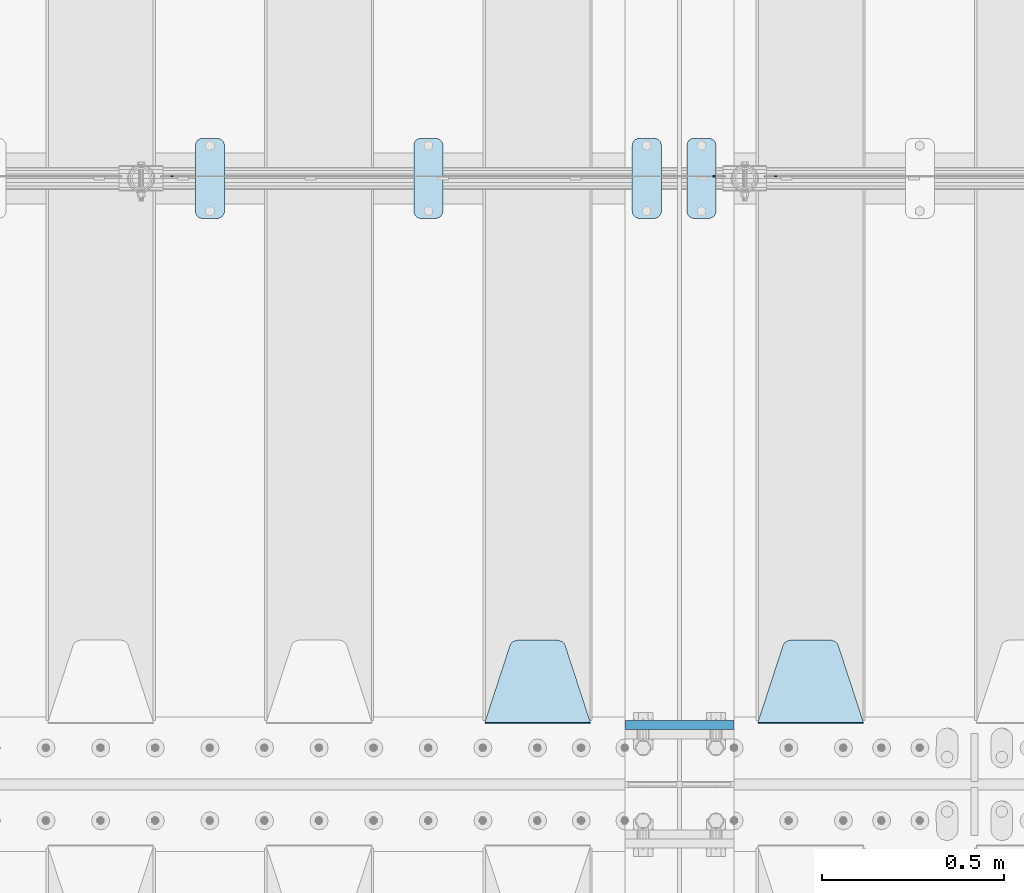
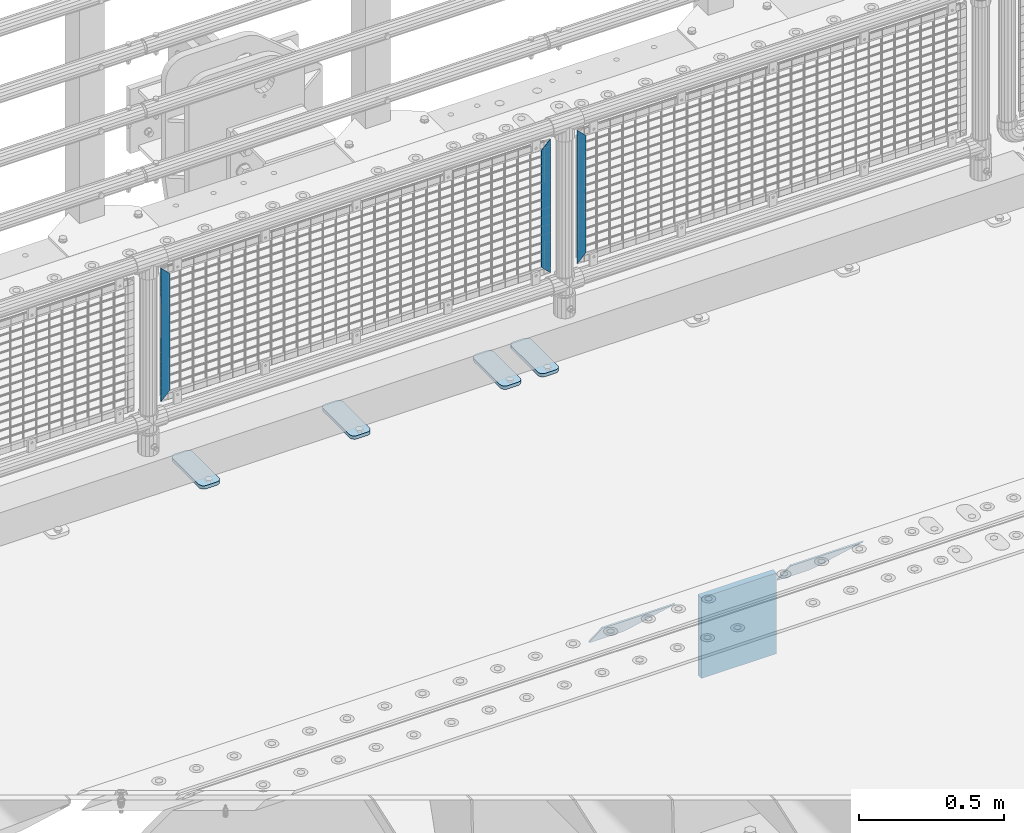
# One storey, part 173 of 193: 10 plates.
"""IFC2X3 building model written with IfcOpenShell, lengths in millimetres."""

from ifc_helpers import new_model, si_unit, frame, origin_with_axes, place, context, subcontext, project, spatial, faceted_brep, material, type_object, element, save


model = new_model("IFC2X3")

# Units and contexts
model_context = context("Model", 3, precision=1e-05, world=origin_with_axes())
body_context = subcontext(model_context, "Body", "Model", "MODEL_VIEW")
ifc_project = project(units=[si_unit("LENGTHUNIT", "METRE", prefix="MILLI"), si_unit("AREAUNIT", "SQUARE_METRE"), si_unit("VOLUMEUNIT", "CUBIC_METRE"), si_unit("MASSUNIT", "GRAM", prefix="KILO"), si_unit("TIMEUNIT", "SECOND"), si_unit("PLANEANGLEUNIT", "RADIAN"), si_unit("SOLIDANGLEUNIT", "STERADIAN"), si_unit("THERMODYNAMICTEMPERATUREUNIT", "DEGREE_CELSIUS"), si_unit("LUMINOUSINTENSITYUNIT", "LUMEN")], contexts=[model_context])

# Site, building, storey
site_placement = place(None, origin_with_axes())
site = spatial("IfcSite", under=ifc_project, at=site_placement, CompositionType="ELEMENT")
building_placement = place(site_placement, origin_with_axes())
building = spatial("IfcBuilding", under=site, at=building_placement, Name="Standard", CompositionType="ELEMENT")
storey_placement = place(building_placement, origin_with_axes())
storey = spatial("IfcBuildingStorey", under=building, at=storey_placement, Name="Undefined", CompositionType="ELEMENT", Elevation=0.0)

# Plates
ifc_material_1 = material(Name="STEEL/S355N")
plate_type_1 = type_object("IfcPlateType", PredefinedType="NOTDEFINED")
plate_1_placement = place(storey_placement, frame((-32210.0, 27162.5, -340.000000000044), z_axis=(0.0, 0.0, 1.0), x_axis=(1.0, 0.0, 0.0)))
element("IfcPlate", 1, at=plate_1_placement, inside=storey, type_object=plate_type_1, material=ifc_material_1, context=body_context, shape_type="Brep", body=[
    faceted_brep([(0.0, -12.5, 0.0), (9.27684595808387e-10, -12.5, 340.0), (9.27684595808387e-10, 12.5, 340.0), (0.0, 12.5, 0.0), (300.0, -12.5, 340.0), (300.0, 12.5, 340.0), (300.0, -12.5, 0.0), (300.0, 12.5, 0.0)], [[[0, 1, 2, 3]], [[1, 4, 5, 2]], [[4, 6, 7, 5]], [[6, 0, 3, 7]], [[5, 7, 3, 2]], [[6, 4, 1, 0]]]),
])
plate_type_2 = type_object("IfcPlateType", PredefinedType="NOTDEFINED")
plate_2_placement = place(storey_placement, frame((-31555.0, 27168.232233047, -1.76776695296758), z_axis=(0.0, 0.707106781186547, -0.707106781186548), x_axis=(-1.0, 0.0, 0.0)))
element("IfcPlate", 2, at=plate_2_placement, inside=storey, type_object=plate_type_2, material=ifc_material_1, context=body_context, shape_type="Brep", body=[
    faceted_brep([(0.0, -2.5, 0.0), (69.345504679477, -2.50000000000364, 300.171731424831), (69.345504679477, 2.49999999999636, 300.171731424831), (0.0, 2.5, 0.0), (70.9274061199576, -2.50000000000364, 304.897442415397), (70.9274061199576, 2.49999999999636, 304.897442415397), (73.3818627772307, -2.50000000000364, 309.234538108529), (73.3818627772307, 2.49999999999636, 309.234538108529), (76.6187032999551, -2.50000000000728, 313.023683126103), (76.6187032999551, 2.49999999999636, 313.023683126103), (80.5190132704993, -2.50000000000364, 316.125672595372), (80.5190132704993, 2.49999999999636, 316.125672595368), (84.9395038596849, -2.50000000000364, 318.426546230472), (84.9395038596849, 2.49999999999636, 318.426546230476), (89.7177759439219, -2.50000000000364, 319.841774983273), (89.7177759439219, 2.49999999999636, 319.841774983277), (94.678286292652, -2.50000000000364, 320.319366455074), (94.678286292652, 2.49999999999636, 320.319366455074), (195.321713707348, -2.50000000000364, 320.319366455074), (195.321713707348, 2.49999999999636, 320.319366455074), (200.282224056078, -2.50000000000364, 319.841774983273), (200.282224056078, 2.49999999999636, 319.841774983277), (205.060496140315, -2.50000000000364, 318.426546230472), (205.060496140315, 2.49999999999636, 318.426546230472), (209.480986729501, -2.50000000000364, 316.125672595372), (209.480986729501, 2.49999999999636, 316.125672595368), (213.381296700045, -2.50000000000728, 313.023683126103), (213.381296700045, 2.49999999999272, 313.023683126103), (216.618137222769, -2.50000000000364, 309.234538108525), (216.618137222769, 2.49999999999636, 309.234538108522), (219.072593880042, -2.50000000000364, 304.897442415397), (219.072593880042, 2.49999999999636, 304.897442415397), (220.654495320523, -2.50000000000364, 300.171731424831), (220.654495320523, 2.49999999999636, 300.171731424831), (290.0, -2.50000000000364, 0.0), (290.0, 2.49999999999636, 0.0)], [[[0, 1, 2, 3]], [[1, 4, 5, 2]], [[4, 6, 7, 5]], [[6, 8, 9, 7]], [[8, 10, 11, 9]], [[10, 12, 13, 11]], [[12, 14, 15, 13]], [[14, 16, 17, 15]], [[16, 18, 19, 17]], [[18, 20, 21, 19]], [[20, 22, 23, 21]], [[22, 24, 25, 23]], [[24, 26, 27, 25]], [[26, 28, 29, 27]], [[28, 30, 31, 29]], [[30, 32, 33, 31]], [[32, 34, 35, 33]], [[34, 0, 3, 35]], [[5, 7, 9, 11, 13, 15, 17, 19, 21, 23, 25, 27, 29, 31, 33, 35, 3, 2]], [[34, 32, 30, 28, 26, 24, 22, 20, 18, 16, 14, 12, 10, 8, 6, 4, 1, 0]]]),
])
plate_3_placement = place(storey_placement, frame((-32305.0, 27168.232233047, -1.76776695296758), z_axis=(0.0, 0.707106781186547, -0.707106781186548), x_axis=(-1.0, 0.0, 0.0)))
element("IfcPlate", 3, at=plate_3_placement, inside=storey, type_object=plate_type_2, material=ifc_material_1, context=body_context, shape_type="Brep", body=[
    faceted_brep([(0.0, -2.5, 0.0), (69.345504679477, -2.50000000000364, 300.171731424831), (69.345504679477, 2.49999999999636, 300.171731424831), (0.0, 2.5, 0.0), (70.9274061199576, -2.50000000000364, 304.897442415397), (70.9274061199576, 2.49999999999636, 304.897442415397), (73.3818627772307, -2.50000000000364, 309.234538108529), (73.3818627772307, 2.49999999999636, 309.234538108529), (76.6187032999551, -2.50000000000728, 313.023683126103), (76.6187032999551, 2.49999999999636, 313.023683126103), (80.5190132704993, -2.50000000000364, 316.125672595372), (80.5190132704993, 2.49999999999636, 316.125672595368), (84.9395038596849, -2.50000000000364, 318.426546230472), (84.9395038596849, 2.49999999999636, 318.426546230476), (89.7177759439219, -2.50000000000364, 319.841774983273), (89.7177759439219, 2.49999999999636, 319.841774983277), (94.678286292652, -2.50000000000364, 320.319366455074), (94.678286292652, 2.49999999999636, 320.319366455074), (195.321713707348, -2.50000000000364, 320.319366455074), (195.321713707348, 2.49999999999636, 320.319366455074), (200.282224056078, -2.50000000000364, 319.841774983273), (200.282224056078, 2.49999999999636, 319.841774983277), (205.060496140315, -2.50000000000364, 318.426546230472), (205.060496140315, 2.49999999999636, 318.426546230472), (209.480986729501, -2.50000000000364, 316.125672595372), (209.480986729501, 2.49999999999636, 316.125672595368), (213.381296700045, -2.50000000000728, 313.023683126103), (213.381296700045, 2.49999999999272, 313.023683126103), (216.618137222769, -2.50000000000364, 309.234538108525), (216.618137222769, 2.49999999999636, 309.234538108522), (219.072593880042, -2.50000000000364, 304.897442415397), (219.072593880042, 2.49999999999636, 304.897442415397), (220.654495320523, -2.50000000000364, 300.171731424831), (220.654495320523, 2.49999999999636, 300.171731424831), (290.0, -2.50000000000364, 0.0), (290.0, 2.49999999999636, 0.0)], [[[0, 1, 2, 3]], [[1, 4, 5, 2]], [[4, 6, 7, 5]], [[6, 8, 9, 7]], [[8, 10, 11, 9]], [[10, 12, 13, 11]], [[12, 14, 15, 13]], [[14, 16, 17, 15]], [[16, 18, 19, 17]], [[18, 20, 21, 19]], [[20, 22, 23, 21]], [[22, 24, 25, 23]], [[24, 26, 27, 25]], [[26, 28, 29, 27]], [[28, 30, 31, 29]], [[30, 32, 33, 31]], [[32, 34, 35, 33]], [[34, 0, 3, 35]], [[5, 7, 9, 11, 13, 15, 17, 19, 21, 23, 25, 27, 29, 31, 33, 35, 3, 2]], [[34, 32, 30, 28, 26, 24, 22, 20, 18, 16, 14, 12, 10, 8, 6, 4, 1, 0]]]),
])
ifc_material_2 = material(Name="Misc_Undefined")
plate_type_3 = type_object("IfcPlateType", PredefinedType="NOTDEFINED")
for number, where, z_axis, x_axis in (
    (4, (-31792.490286459, 28670.5, 879.519963133601), (-0.707008801899319, 0.0, -0.707204746899291), (-0.70720474689929, 0.0, 0.707008801899319)),
    (5, (-33450.490286459, 28670.5, 879.519963133601), (-0.707008801899319, 0.0, -0.707204746899291), (-0.70720474689929, 0.0, 0.707008801899319)),
):
    element("IfcPlate", number, at=place(storey_placement, frame(where, z_axis=z_axis, x_axis=x_axis)), inside=storey, type_object=plate_type_3, material=ifc_material_2, context=body_context, shape_type="Brep", body=[
        faceted_brep([(0.0, -1.49999999999636, 3.63797880709171e-12), (-348.552185058594, -1.5, 348.655029296875), (-348.552185058594, 1.5, 348.655029296875), (0.0, 1.50000000000364, 7.27595761418343e-12), (-348.544891357422, -1.5, 398.152496337891), (-348.544891357422, 1.5, 398.152496337891), (49.50439453125, -1.5, 7.6397554948926e-11), (49.50439453125, 1.5, 7.6397554948926e-11)], [[[0, 1, 2, 3]], [[1, 4, 5, 2]], [[4, 6, 7, 5]], [[6, 0, 3, 7]], [[5, 7, 3, 2]], [[6, 4, 1, 0]]]),
    ])
plate_4_placement = place(storey_placement, frame((-31969.5003125164, 28670.5, 879.52), z_axis=(0.707103624179499, 0.0, -0.707109938179501), x_axis=(0.707109938179495, 0.0, 0.707103624179505)))
element("IfcPlate", 6, at=plate_4_placement, inside=storey, type_object=plate_type_3, material=ifc_material_2, context=body_context, shape_type="Brep", body=[
    faceted_brep([(0.0, -1.49999999999636, 3.63797880709171e-12), (-348.605163574215, -1.5, 348.602081298824), (-348.605163574215, 1.5, 348.602081298824), (0.0, 1.50000000000364, 7.27595761418343e-12), (-348.605163574215, -1.5, 398.099334716793), (-348.605163574215, 1.5, 398.099334716793), (49.4976959228552, -1.5, -1.01863406598568e-10), (49.4976959228552, 1.5, -1.01863406598568e-10)], [[[0, 1, 2, 3]], [[1, 4, 5, 2]], [[4, 6, 7, 5]], [[6, 0, 3, 7]], [[5, 7, 3, 2]], [[6, 4, 1, 0]]]),
])
ifc_material_3 = material(Name="STEEL/S355J2")
plate_type_4 = type_object("IfcPlateType", PredefinedType="NOTDEFINED")
plate_5_placement = place(storey_placement, frame((-32190.0, 28774.5, 21.0199999999977), z_axis=(1.0, 0.0, 0.0), x_axis=(0.0, -1.0, 0.0)))
element("IfcPlate", 7, at=plate_5_placement, inside=storey, type_object=plate_type_4, material=ifc_material_3, context=body_context, shape_type="Brep", body=[
    faceted_brep([(0.0, -7.0, 20.0), (0.0, -7.0, 60.0), (0.0, 7.0, 60.0), (0.0, 7.0, 20.0), (0.384294391937146, -7.0, 63.9018064403208), (0.384294391937146, 7.0, 63.9018064403208), (1.52240934977453, -7.0, 67.6536686473009), (1.52240934977453, 7.0, 67.6536686473009), (3.37060775395003, -7.0, 71.1114046603907), (3.37060775395003, 7.0, 71.1114046603907), (5.8578643762703, -7.0, 74.1421356237297), (5.8578643762703, 7.0, 74.1421356237297), (8.88859533960931, -7.0, 76.62939224605), (8.88859533960931, 7.0, 76.62939224605), (12.3463313526991, -7.0, 78.4775906502255), (12.3463313526991, 7.0, 78.4775906502255), (16.0981935596792, -7.0, 79.6157056080629), (16.0981935596792, 7.0, 79.6157056080629), (20.0, -7.0, 80.0), (20.0, 7.0, 80.0), (200.0, -7.0, 80.0), (200.0, 7.0, 80.0), (203.901806440321, -7.0, 79.6157056080629), (203.901806440321, 7.0, 79.6157056080629), (207.653668647301, -7.0, 78.4775906502255), (207.653668647301, 7.0, 78.4775906502255), (211.111404660391, -7.0, 76.62939224605), (211.111404660391, 7.0, 76.62939224605), (214.14213562373, -7.0, 74.1421356237297), (214.14213562373, 7.0, 74.1421356237297), (216.62939224605, -7.0, 71.1114046603907), (216.62939224605, 7.0, 71.1114046603907), (218.477590650225, -7.0, 67.6536686473009), (218.477590650225, 7.0, 67.6536686473009), (219.615705608063, -7.0, 63.9018064403208), (219.615705608063, 7.0, 63.9018064403208), (220.0, -7.0, 60.0), (220.0, 7.0, 60.0), (220.0, -7.0, 20.0), (220.0, 7.0, 20.0), (219.615705608063, -7.0, 16.0981935596792), (219.615705608063, 7.0, 16.0981935596792), (218.477590650225, -7.0, 12.3463313526991), (218.477590650225, 7.0, 12.3463313526991), (216.62939224605, -7.0, 8.88859533960931), (216.62939224605, 7.0, 8.88859533960931), (214.14213562373, -7.0, 5.8578643762703), (214.14213562373, 7.0, 5.8578643762703), (211.111404660391, -7.0, 3.37060775395003), (211.111404660391, 7.0, 3.37060775395003), (207.653668647301, -7.0, 1.52240934977453), (207.653668647301, 7.0, 1.52240934977453), (203.901806440321, -7.0, 0.384294391937146), (203.901806440321, 7.0, 0.384294391937146), (200.0, -7.0, 0.0), (200.0, 7.0, 0.0), (20.0, -7.0, 0.0), (20.0, 7.0, 0.0), (16.0981935596792, -7.0, 0.384294391937146), (16.0981935596792, 7.0, 0.384294391937146), (12.3463313526991, -7.0, 1.52240934977453), (12.3463313526991, 7.0, 1.52240934977453), (8.88859533960931, -7.0, 3.37060775395003), (8.88859533960931, 7.0, 3.37060775395003), (5.8578643762703, -7.0, 5.8578643762703), (5.8578643762703, 7.0, 5.8578643762703), (3.37060775395003, -7.0, 8.88859533960931), (3.37060775395003, 7.0, 8.88859533960931), (1.52240934977453, -7.0, 12.3463313526991), (1.52240934977453, 7.0, 12.3463313526991), (0.384294391937146, -7.0, 16.0981935596792), (0.384294391937146, 7.0, 16.0981935596792)], [[[0, 1, 2, 3]], [[1, 4, 5, 2]], [[4, 6, 7, 5]], [[6, 8, 9, 7]], [[8, 10, 11, 9]], [[10, 12, 13, 11]], [[12, 14, 15, 13]], [[14, 16, 17, 15]], [[16, 18, 19, 17]], [[18, 20, 21, 19]], [[20, 22, 23, 21]], [[22, 24, 25, 23]], [[24, 26, 27, 25]], [[26, 28, 29, 27]], [[28, 30, 31, 29]], [[30, 32, 33, 31]], [[32, 34, 35, 33]], [[34, 36, 37, 35]], [[36, 38, 39, 37]], [[38, 40, 41, 39]], [[40, 42, 43, 41]], [[42, 44, 45, 43]], [[44, 46, 47, 45]], [[46, 48, 49, 47]], [[48, 50, 51, 49]], [[50, 52, 53, 51]], [[52, 54, 55, 53]], [[54, 56, 57, 55]], [[56, 58, 59, 57]], [[58, 60, 61, 59]], [[60, 62, 63, 61]], [[62, 64, 65, 63]], [[64, 66, 67, 65]], [[66, 68, 69, 67]], [[68, 70, 71, 69]], [[70, 0, 3, 71]], [[5, 7, 9, 11, 13, 15, 17, 19, 21, 23, 25, 27, 29, 31, 33, 35, 37, 39, 41, 43, 45, 47, 49, 51, 53, 55, 57, 59, 61, 63, 65, 67, 69, 71, 3, 2]], [[70, 68, 66, 64, 62, 60, 58, 56, 54, 52, 50, 48, 46, 44, 42, 40, 38, 36, 34, 32, 30, 28, 26, 24, 22, 20, 18, 16, 14, 12, 10, 8, 6, 4, 1, 0]]]),
])
plate_6_placement = place(storey_placement, frame((-32040.0, 28774.5, 21.0199999999977), z_axis=(1.0, 0.0, 0.0), x_axis=(0.0, -1.0, 0.0)))
element("IfcPlate", 8, at=plate_6_placement, inside=storey, type_object=plate_type_4, material=ifc_material_3, context=body_context, shape_type="Brep", body=[
    faceted_brep([(0.0, -7.0, 20.0), (0.0, -7.0, 60.0), (0.0, 7.0, 60.0), (0.0, 7.0, 20.0), (0.384294391937146, -7.0, 63.9018064403208), (0.384294391937146, 7.0, 63.9018064403208), (1.52240934977453, -7.0, 67.6536686473009), (1.52240934977453, 7.0, 67.6536686473009), (3.37060775395003, -7.0, 71.1114046603907), (3.37060775395003, 7.0, 71.1114046603907), (5.8578643762703, -7.0, 74.1421356237297), (5.8578643762703, 7.0, 74.1421356237297), (8.88859533960931, -7.0, 76.62939224605), (8.88859533960931, 7.0, 76.62939224605), (12.3463313526991, -7.0, 78.4775906502255), (12.3463313526991, 7.0, 78.4775906502255), (16.0981935596792, -7.0, 79.6157056080629), (16.0981935596792, 7.0, 79.6157056080629), (20.0, -7.0, 80.0), (20.0, 7.0, 80.0), (200.0, -7.0, 80.0), (200.0, 7.0, 80.0), (203.901806440321, -7.0, 79.6157056080629), (203.901806440321, 7.0, 79.6157056080629), (207.653668647301, -7.0, 78.4775906502255), (207.653668647301, 7.0, 78.4775906502255), (211.111404660391, -7.0, 76.62939224605), (211.111404660391, 7.0, 76.62939224605), (214.14213562373, -7.0, 74.1421356237297), (214.14213562373, 7.0, 74.1421356237297), (216.62939224605, -7.0, 71.1114046603907), (216.62939224605, 7.0, 71.1114046603907), (218.477590650225, -7.0, 67.6536686473009), (218.477590650225, 7.0, 67.6536686473009), (219.615705608063, -7.0, 63.9018064403208), (219.615705608063, 7.0, 63.9018064403208), (220.0, -7.0, 60.0), (220.0, 7.0, 60.0), (220.0, -7.0, 20.0), (220.0, 7.0, 20.0), (219.615705608063, -7.0, 16.0981935596792), (219.615705608063, 7.0, 16.0981935596792), (218.477590650225, -7.0, 12.3463313526991), (218.477590650225, 7.0, 12.3463313526991), (216.62939224605, -7.0, 8.88859533960931), (216.62939224605, 7.0, 8.88859533960931), (214.14213562373, -7.0, 5.8578643762703), (214.14213562373, 7.0, 5.8578643762703), (211.111404660391, -7.0, 3.37060775395003), (211.111404660391, 7.0, 3.37060775395003), (207.653668647301, -7.0, 1.52240934977453), (207.653668647301, 7.0, 1.52240934977453), (203.901806440321, -7.0, 0.384294391937146), (203.901806440321, 7.0, 0.384294391937146), (200.0, -7.0, 0.0), (200.0, 7.0, 0.0), (20.0, -7.0, 0.0), (20.0, 7.0, 0.0), (16.0981935596792, -7.0, 0.384294391937146), (16.0981935596792, 7.0, 0.384294391937146), (12.3463313526991, -7.0, 1.52240934977453), (12.3463313526991, 7.0, 1.52240934977453), (8.88859533960931, -7.0, 3.37060775395003), (8.88859533960931, 7.0, 3.37060775395003), (5.8578643762703, -7.0, 5.8578643762703), (5.8578643762703, 7.0, 5.8578643762703), (3.37060775395003, -7.0, 8.88859533960931), (3.37060775395003, 7.0, 8.88859533960931), (1.52240934977453, -7.0, 12.3463313526991), (1.52240934977453, 7.0, 12.3463313526991), (0.384294391937146, -7.0, 16.0981935596792), (0.384294391937146, 7.0, 16.0981935596792)], [[[0, 1, 2, 3]], [[1, 4, 5, 2]], [[4, 6, 7, 5]], [[6, 8, 9, 7]], [[8, 10, 11, 9]], [[10, 12, 13, 11]], [[12, 14, 15, 13]], [[14, 16, 17, 15]], [[16, 18, 19, 17]], [[18, 20, 21, 19]], [[20, 22, 23, 21]], [[22, 24, 25, 23]], [[24, 26, 27, 25]], [[26, 28, 29, 27]], [[28, 30, 31, 29]], [[30, 32, 33, 31]], [[32, 34, 35, 33]], [[34, 36, 37, 35]], [[36, 38, 39, 37]], [[38, 40, 41, 39]], [[40, 42, 43, 41]], [[42, 44, 45, 43]], [[44, 46, 47, 45]], [[46, 48, 49, 47]], [[48, 50, 51, 49]], [[50, 52, 53, 51]], [[52, 54, 55, 53]], [[54, 56, 57, 55]], [[56, 58, 59, 57]], [[58, 60, 61, 59]], [[60, 62, 63, 61]], [[62, 64, 65, 63]], [[64, 66, 67, 65]], [[66, 68, 69, 67]], [[68, 70, 71, 69]], [[70, 0, 3, 71]], [[5, 7, 9, 11, 13, 15, 17, 19, 21, 23, 25, 27, 29, 31, 33, 35, 37, 39, 41, 43, 45, 47, 49, 51, 53, 55, 57, 59, 61, 63, 65, 67, 69, 71, 3, 2]], [[70, 68, 66, 64, 62, 60, 58, 56, 54, 52, 50, 48, 46, 44, 42, 40, 38, 36, 34, 32, 30, 28, 26, 24, 22, 20, 18, 16, 14, 12, 10, 8, 6, 4, 1, 0]]]),
])
plate_7_placement = place(storey_placement, frame((-32790.0, 28774.5, 21.0199999999977), z_axis=(1.0, 0.0, 0.0), x_axis=(0.0, -1.0, 0.0)))
element("IfcPlate", 9, at=plate_7_placement, inside=storey, type_object=plate_type_4, material=ifc_material_3, context=body_context, shape_type="Brep", body=[
    faceted_brep([(0.0, -7.0, 20.0), (0.0, -7.0, 60.0), (0.0, 7.0, 60.0), (0.0, 7.0, 20.0), (0.384294391937146, -7.0, 63.9018064403208), (0.384294391937146, 7.0, 63.9018064403208), (1.52240934977453, -7.0, 67.6536686473009), (1.52240934977453, 7.0, 67.6536686473009), (3.37060775395003, -7.0, 71.1114046603907), (3.37060775395003, 7.0, 71.1114046603907), (5.8578643762703, -7.0, 74.1421356237297), (5.8578643762703, 7.0, 74.1421356237297), (8.88859533960931, -7.0, 76.62939224605), (8.88859533960931, 7.0, 76.62939224605), (12.3463313526991, -7.0, 78.4775906502255), (12.3463313526991, 7.0, 78.4775906502255), (16.0981935596792, -7.0, 79.6157056080629), (16.0981935596792, 7.0, 79.6157056080629), (20.0, -7.0, 80.0), (20.0, 7.0, 80.0), (200.0, -7.0, 80.0), (200.0, 7.0, 80.0), (203.901806440321, -7.0, 79.6157056080629), (203.901806440321, 7.0, 79.6157056080629), (207.653668647301, -7.0, 78.4775906502255), (207.653668647301, 7.0, 78.4775906502255), (211.111404660391, -7.0, 76.62939224605), (211.111404660391, 7.0, 76.62939224605), (214.14213562373, -7.0, 74.1421356237297), (214.14213562373, 7.0, 74.1421356237297), (216.62939224605, -7.0, 71.1114046603907), (216.62939224605, 7.0, 71.1114046603907), (218.477590650225, -7.0, 67.6536686473009), (218.477590650225, 7.0, 67.6536686473009), (219.615705608063, -7.0, 63.9018064403208), (219.615705608063, 7.0, 63.9018064403208), (220.0, -7.0, 60.0), (220.0, 7.0, 60.0), (220.0, -7.0, 20.0), (220.0, 7.0, 20.0), (219.615705608063, -7.0, 16.0981935596792), (219.615705608063, 7.0, 16.0981935596792), (218.477590650225, -7.0, 12.3463313526991), (218.477590650225, 7.0, 12.3463313526991), (216.62939224605, -7.0, 8.88859533960931), (216.62939224605, 7.0, 8.88859533960931), (214.14213562373, -7.0, 5.8578643762703), (214.14213562373, 7.0, 5.8578643762703), (211.111404660391, -7.0, 3.37060775395003), (211.111404660391, 7.0, 3.37060775395003), (207.653668647301, -7.0, 1.52240934977453), (207.653668647301, 7.0, 1.52240934977453), (203.901806440321, -7.0, 0.384294391937146), (203.901806440321, 7.0, 0.384294391937146), (200.0, -7.0, 0.0), (200.0, 7.0, 0.0), (20.0, -7.0, 0.0), (20.0, 7.0, 0.0), (16.0981935596792, -7.0, 0.384294391937146), (16.0981935596792, 7.0, 0.384294391937146), (12.3463313526991, -7.0, 1.52240934977453), (12.3463313526991, 7.0, 1.52240934977453), (8.88859533960931, -7.0, 3.37060775395003), (8.88859533960931, 7.0, 3.37060775395003), (5.8578643762703, -7.0, 5.8578643762703), (5.8578643762703, 7.0, 5.8578643762703), (3.37060775395003, -7.0, 8.88859533960931), (3.37060775395003, 7.0, 8.88859533960931), (1.52240934977453, -7.0, 12.3463313526991), (1.52240934977453, 7.0, 12.3463313526991), (0.384294391937146, -7.0, 16.0981935596792), (0.384294391937146, 7.0, 16.0981935596792)], [[[0, 1, 2, 3]], [[1, 4, 5, 2]], [[4, 6, 7, 5]], [[6, 8, 9, 7]], [[8, 10, 11, 9]], [[10, 12, 13, 11]], [[12, 14, 15, 13]], [[14, 16, 17, 15]], [[16, 18, 19, 17]], [[18, 20, 21, 19]], [[20, 22, 23, 21]], [[22, 24, 25, 23]], [[24, 26, 27, 25]], [[26, 28, 29, 27]], [[28, 30, 31, 29]], [[30, 32, 33, 31]], [[32, 34, 35, 33]], [[34, 36, 37, 35]], [[36, 38, 39, 37]], [[38, 40, 41, 39]], [[40, 42, 43, 41]], [[42, 44, 45, 43]], [[44, 46, 47, 45]], [[46, 48, 49, 47]], [[48, 50, 51, 49]], [[50, 52, 53, 51]], [[52, 54, 55, 53]], [[54, 56, 57, 55]], [[56, 58, 59, 57]], [[58, 60, 61, 59]], [[60, 62, 63, 61]], [[62, 64, 65, 63]], [[64, 66, 67, 65]], [[66, 68, 69, 67]], [[68, 70, 71, 69]], [[70, 0, 3, 71]], [[5, 7, 9, 11, 13, 15, 17, 19, 21, 23, 25, 27, 29, 31, 33, 35, 37, 39, 41, 43, 45, 47, 49, 51, 53, 55, 57, 59, 61, 63, 65, 67, 69, 71, 3, 2]], [[70, 68, 66, 64, 62, 60, 58, 56, 54, 52, 50, 48, 46, 44, 42, 40, 38, 36, 34, 32, 30, 28, 26, 24, 22, 20, 18, 16, 14, 12, 10, 8, 6, 4, 1, 0]]]),
])
plate_8_placement = place(storey_placement, frame((-33390.0, 28774.5, 21.0199999999977), z_axis=(1.0, 0.0, 0.0), x_axis=(0.0, -1.0, 0.0)))
element("IfcPlate", 10, at=plate_8_placement, inside=storey, type_object=plate_type_4, material=ifc_material_3, context=body_context, shape_type="Brep", body=[
    faceted_brep([(0.0, -7.0, 20.0), (0.0, -7.0, 60.0), (0.0, 7.0, 60.0), (0.0, 7.0, 20.0), (0.384294391937146, -7.0, 63.9018064403208), (0.384294391937146, 7.0, 63.9018064403208), (1.52240934977453, -7.0, 67.6536686473009), (1.52240934977453, 7.0, 67.6536686473009), (3.37060775395003, -7.0, 71.1114046603907), (3.37060775395003, 7.0, 71.1114046603907), (5.8578643762703, -7.0, 74.1421356237297), (5.8578643762703, 7.0, 74.1421356237297), (8.88859533960931, -7.0, 76.62939224605), (8.88859533960931, 7.0, 76.62939224605), (12.3463313526991, -7.0, 78.4775906502255), (12.3463313526991, 7.0, 78.4775906502255), (16.0981935596792, -7.0, 79.6157056080629), (16.0981935596792, 7.0, 79.6157056080629), (20.0, -7.0, 80.0), (20.0, 7.0, 80.0), (200.0, -7.0, 80.0), (200.0, 7.0, 80.0), (203.901806440321, -7.0, 79.6157056080629), (203.901806440321, 7.0, 79.6157056080629), (207.653668647301, -7.0, 78.4775906502255), (207.653668647301, 7.0, 78.4775906502255), (211.111404660391, -7.0, 76.62939224605), (211.111404660391, 7.0, 76.62939224605), (214.14213562373, -7.0, 74.1421356237297), (214.14213562373, 7.0, 74.1421356237297), (216.62939224605, -7.0, 71.1114046603907), (216.62939224605, 7.0, 71.1114046603907), (218.477590650225, -7.0, 67.6536686473009), (218.477590650225, 7.0, 67.6536686473009), (219.615705608063, -7.0, 63.9018064403208), (219.615705608063, 7.0, 63.9018064403208), (220.0, -7.0, 60.0), (220.0, 7.0, 60.0), (220.0, -7.0, 20.0), (220.0, 7.0, 20.0), (219.615705608063, -7.0, 16.0981935596792), (219.615705608063, 7.0, 16.0981935596792), (218.477590650225, -7.0, 12.3463313526991), (218.477590650225, 7.0, 12.3463313526991), (216.62939224605, -7.0, 8.88859533960931), (216.62939224605, 7.0, 8.88859533960931), (214.14213562373, -7.0, 5.8578643762703), (214.14213562373, 7.0, 5.8578643762703), (211.111404660391, -7.0, 3.37060775395003), (211.111404660391, 7.0, 3.37060775395003), (207.653668647301, -7.0, 1.52240934977453), (207.653668647301, 7.0, 1.52240934977453), (203.901806440321, -7.0, 0.384294391937146), (203.901806440321, 7.0, 0.384294391937146), (200.0, -7.0, 0.0), (200.0, 7.0, 0.0), (20.0, -7.0, 0.0), (20.0, 7.0, 0.0), (16.0981935596792, -7.0, 0.384294391937146), (16.0981935596792, 7.0, 0.384294391937146), (12.3463313526991, -7.0, 1.52240934977453), (12.3463313526991, 7.0, 1.52240934977453), (8.88859533960931, -7.0, 3.37060775395003), (8.88859533960931, 7.0, 3.37060775395003), (5.8578643762703, -7.0, 5.8578643762703), (5.8578643762703, 7.0, 5.8578643762703), (3.37060775395003, -7.0, 8.88859533960931), (3.37060775395003, 7.0, 8.88859533960931), (1.52240934977453, -7.0, 12.3463313526991), (1.52240934977453, 7.0, 12.3463313526991), (0.384294391937146, -7.0, 16.0981935596792), (0.384294391937146, 7.0, 16.0981935596792)], [[[0, 1, 2, 3]], [[1, 4, 5, 2]], [[4, 6, 7, 5]], [[6, 8, 9, 7]], [[8, 10, 11, 9]], [[10, 12, 13, 11]], [[12, 14, 15, 13]], [[14, 16, 17, 15]], [[16, 18, 19, 17]], [[18, 20, 21, 19]], [[20, 22, 23, 21]], [[22, 24, 25, 23]], [[24, 26, 27, 25]], [[26, 28, 29, 27]], [[28, 30, 31, 29]], [[30, 32, 33, 31]], [[32, 34, 35, 33]], [[34, 36, 37, 35]], [[36, 38, 39, 37]], [[38, 40, 41, 39]], [[40, 42, 43, 41]], [[42, 44, 45, 43]], [[44, 46, 47, 45]], [[46, 48, 49, 47]], [[48, 50, 51, 49]], [[50, 52, 53, 51]], [[52, 54, 55, 53]], [[54, 56, 57, 55]], [[56, 58, 59, 57]], [[58, 60, 61, 59]], [[60, 62, 63, 61]], [[62, 64, 65, 63]], [[64, 66, 67, 65]], [[66, 68, 69, 67]], [[68, 70, 71, 69]], [[70, 0, 3, 71]], [[5, 7, 9, 11, 13, 15, 17, 19, 21, 23, 25, 27, 29, 31, 33, 35, 37, 39, 41, 43, 45, 47, 49, 51, 53, 55, 57, 59, 61, 63, 65, 67, 69, 71, 3, 2]], [[70, 68, 66, 64, 62, 60, 58, 56, 54, 52, 50, 48, 46, 44, 42, 40, 38, 36, 34, 32, 30, 28, 26, 24, 22, 20, 18, 16, 14, 12, 10, 8, 6, 4, 1, 0]]]),
])

save(model, "model.ifc")
